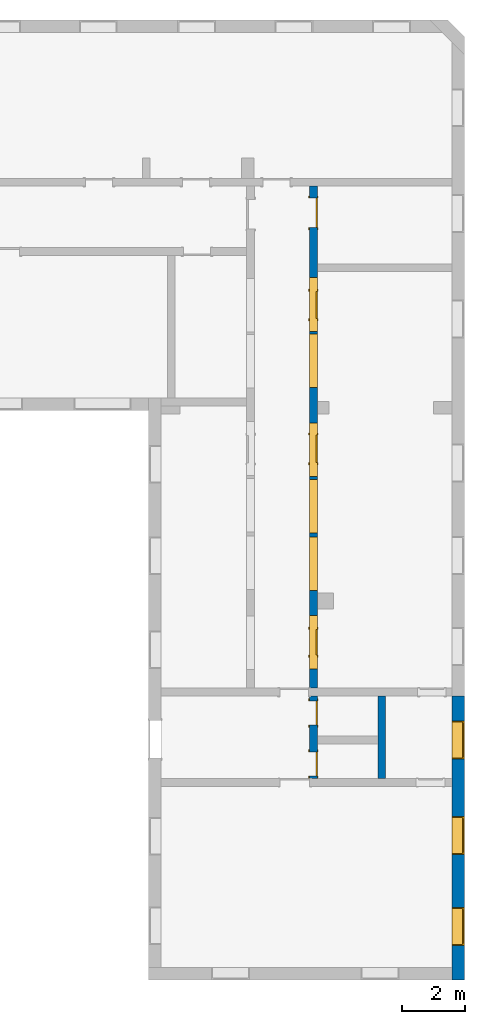
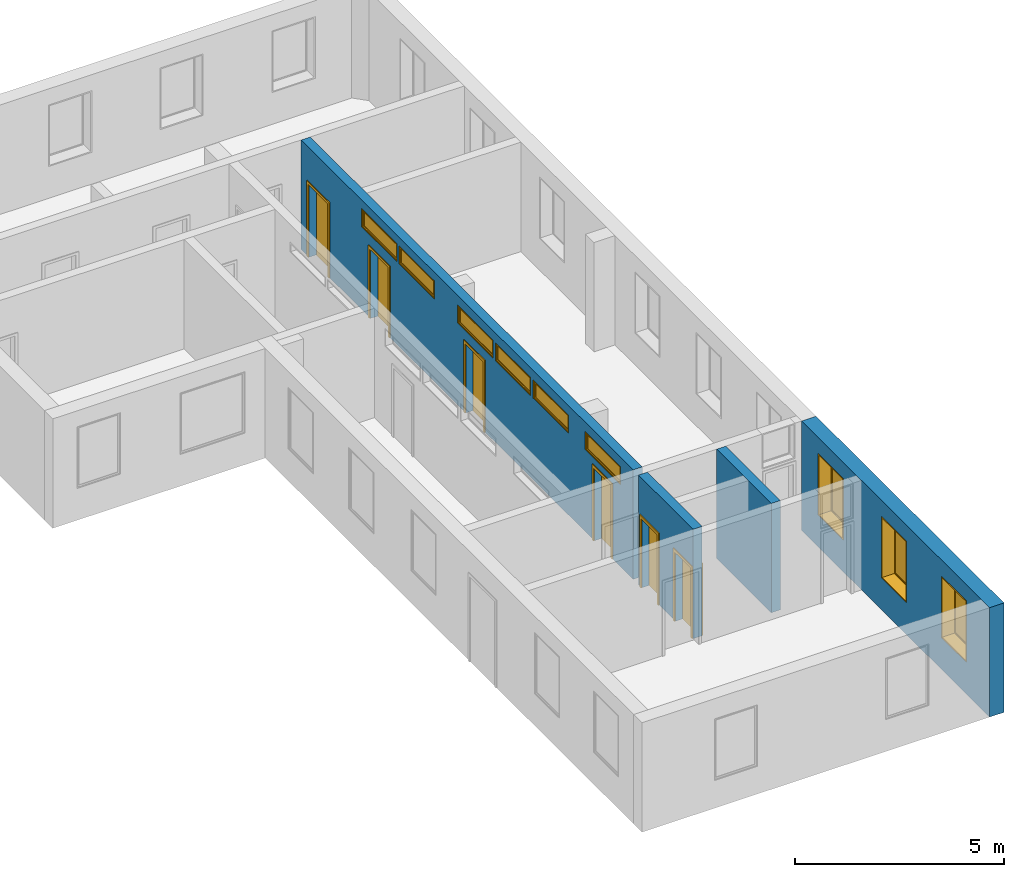
"""IFC2X3 building model written with IfcOpenShell, lengths in millimetres."""

from ifc_helpers import new_model, entity, si_unit, converted_unit, derived_unit, direction, frame, frame_2d, origin, origin_2d_with_axis, place, context, subcontext, project, spatial, polyline, rectangle, outline, extrude, source, transform, mapped, material, material_list, layer, layer_set, layer_usage, type_object, type_shapes, element, fill, save


model = new_model("IFC2X3")

# Units and contexts
model_context = context("Model", 3, precision=0.01, world=origin(), true_north=direction((6.12303176911189e-17, 1.0)))
context_of_model = context(None, 3, precision=0.01, world=origin(), true_north=direction((6.12303176911189e-17, 1.0)))
body_context = subcontext(model_context, "Body", "Model", "MODEL_VIEW")
ifc_project = project(units=[si_unit("LENGTHUNIT", "METRE", prefix="MILLI"), si_unit("AREAUNIT", "SQUARE_METRE"), si_unit("VOLUMEUNIT", "CUBIC_METRE"), converted_unit("PLANEANGLEUNIT", "DEGREE", entity("IfcRatioMeasure", 0.0174532925199433), si_unit("PLANEANGLEUNIT", "RADIAN"), dimensions=[0, 0, 0, 0, 0, 0, 0]), si_unit("MASSUNIT", "GRAM", prefix="KILO"), si_unit("TIMEUNIT", "SECOND"), si_unit("FREQUENCYUNIT", "HERTZ"), si_unit("THERMODYNAMICTEMPERATUREUNIT", "DEGREE_CELSIUS"), derived_unit("THERMALTRANSMITTANCEUNIT", [(si_unit("MASSUNIT", "GRAM", prefix="KILO"), 1), (si_unit("THERMODYNAMICTEMPERATUREUNIT", "KELVIN"), -1), (si_unit("TIMEUNIT", "SECOND"), -3)]), derived_unit("VOLUMETRICFLOWRATEUNIT", [(si_unit("LENGTHUNIT", "METRE"), 3), (si_unit("TIMEUNIT", "SECOND"), -1)]), si_unit("ELECTRICCURRENTUNIT", "AMPERE"), si_unit("ELECTRICVOLTAGEUNIT", "VOLT"), si_unit("POWERUNIT", "WATT"), si_unit("FORCEUNIT", "NEWTON", prefix="KILO"), si_unit("ILLUMINANCEUNIT", "LUX"), si_unit("LUMINOUSFLUXUNIT", "LUMEN"), si_unit("LUMINOUSINTENSITYUNIT", "CANDELA"), si_unit("PRESSUREUNIT", "PASCAL")], contexts=[model_context, context_of_model])

# Site, building, storey
site_placement = place(None, origin())
site = spatial("IfcSite", under=ifc_project, at=site_placement, CompositionType="ELEMENT")
building_placement = place(site_placement, origin())
building = spatial("IfcBuilding", under=site, at=building_placement, CompositionType="ELEMENT")
storey_1_placement = place(building_placement, origin())
storey_1 = spatial("IfcBuildingStorey", under=building, at=storey_1_placement, Name="i Plan", CompositionType="ELEMENT", Elevation=-5.41433564649196e-13)

# Wall, openings
ifc_material_1 = material(Name="Brick, Common")
ifc_layer_1 = layer(ifc_material_1, 400.0)
ifc_layer_set_1 = layer_set([ifc_layer_1], Name="Basic Wall:400mm")
ifc_layer_usage_1 = layer_usage(ifc_layer_set_1, "AXIS2", "NEGATIVE", 200.0)
wall_type_1 = type_object("IfcWallType", Name="Basic Wall:400mm", PredefinedType="STANDARD", material=ifc_layer_set_1)
wall_1_placement = place(storey_1_placement, frame((5302.04003710834, -6813.09629601623, 0.0), z_axis=(0.0, 0.0, 1.0), x_axis=(0.0, -1.0, 0.0)))
wall_1 = element("IfcWallStandardCase", 1, at=wall_1_placement, inside=storey_1, type_object=wall_type_1, material=ifc_layer_usage_1, Name="Basic Wall:400mm", ObjectType="Basic Wall:400mm", context=body_context, shape_type="SweptSolid", body=[
    extrude(rectangle(XDim=9002.31192837113, YDim=400.0, at=frame_2d((4501.15596418557, 2.8421709430404e-14), x_axis=(-1.0, 0.0))), origin(), (0.0, 0.0, 1.0), 3199.99999999984),
])
opening_1_placement = place(wall_1_placement, frame((796.09398524179, -200.0, 930.0)))
opening_1 = element("IfcOpeningElement", 2, at=opening_1_placement, cuts=wall_1, Name="M_Fixed:72_1", ObjectType="Opening", context=body_context, shape_type="SweptSolid", body=[
    extrude(rectangle(XDim=1800.0, YDim=1200.0, at=frame_2d((899.999999999998, 600.0), x_axis=(1.0, 0.0))), frame((0.0, 0.0, 0.0), z_axis=(0.0, 1.0, 0.0), x_axis=(0.0, 0.0, 1.0)), (0.0, 0.0, 1.0), 400.0),
])
opening_2_placement = place(wall_1_placement, frame((3826.09398524179, -200.0, 930.0)))
opening_2 = element("IfcOpeningElement", 3, at=opening_2_placement, cuts=wall_1, Name="M_Fixed:72_1", ObjectType="Opening", context=body_context, shape_type="SweptSolid", body=[
    extrude(rectangle(XDim=1800.0, YDim=1200.0, at=frame_2d((899.999999999998, 600.0), x_axis=(1.0, 0.0))), frame((0.0, 0.0, 0.0), z_axis=(0.0, 1.0, 0.0), x_axis=(0.0, 0.0, 1.0)), (0.0, 0.0, 1.0), 400.0),
])
opening_3_placement = place(wall_1_placement, frame((6702.31192837113, -200.0, 930.0)))
opening_3 = element("IfcOpeningElement", 4, at=opening_3_placement, cuts=wall_1, Name="M_Fixed:72_1", ObjectType="Opening", context=body_context, shape_type="SweptSolid", body=[
    extrude(rectangle(XDim=1800.0, YDim=1200.0, at=frame_2d((899.999999999998, 600.0), x_axis=(1.0, 0.0))), frame((0.0, 0.0, 0.0), z_axis=(0.0, 1.0, 0.0), x_axis=(0.0, 0.0, 1.0)), (0.0, 0.0, 1.0), 400.0),
])

# Storey
storey_2_placement = place(building_placement, frame((0.0, 0.0, 960.0)))
storey_2 = spatial("IfcBuildingStorey", under=building, at=storey_2_placement, Name="Bottom windows", CompositionType="ELEMENT", Elevation=959.999999999999)

# Window
ifc_material_2 = material(Name="Glass")
ifc_material_3 = material(Name="Sash")
ifc_material_list_1 = material_list([ifc_material_2, ifc_material_3])
ifc_material_list_2 = material_list([ifc_material_2, ifc_material_3])
window_style_1 = type_object("IfcWindowStyle", Name="72", ConstructionType="NOTDEFINED", OperationType="NOTDEFINED", ParameterTakesPrecedence=False, Sizeable=False, material=ifc_material_list_2)
shared_shape_1 = source(origin(), body_context, "Body", "SweptSolid", [
    extrude(rectangle(XDim=12.0, YDim=1074.0, at=origin_2d_with_axis()), frame((600.0, 359.0, 63.0), z_axis=(0.0, 0.0, 1.0), x_axis=(0.0, -1.0, 0.0)), (0.0, 0.0, 1.0), 1674.0),
    extrude(outline(polyline([(-581.0, -881.0), (581.0, -881.0), (581.0, 881.0), (-581.0, 881.0), (-581.0, -881.0)]), holes=[polyline([(-537.0, -837.0), (-537.0, 837.0), (537.0, 837.0), (537.0, -837.0), (-537.0, -837.0)])]), frame((600.0, 337.0, 900.0), z_axis=(0.0, 1.0, 0.0), x_axis=(1.0, 0.0, 0.0)), (0.0, 0.0, 1.0), 44.0000000000274),
    extrude(outline(polyline([(-600.0, -900.0), (600.0, -900.0), (600.0, 900.0), (-600.0, 900.0), (-600.0, -900.0)]), holes=[polyline([(-581.0, -881.0), (-581.0, 881.0), (581.0, 881.0), (581.0, -881.0), (-581.0, -881.0)])]), frame((600.0, 337.0, 900.0), z_axis=(0.0, 1.0, 0.0), x_axis=(1.0, 0.0, 0.0)), (0.0, 0.0, 1.0), 63.0000000000275),
    extrude(outline(polyline([(-600.0, -900.0), (600.0, -900.0), (600.0, 900.0), (-600.0, 900.0), (-600.0, -900.0)]), holes=[polyline([(-568.0, -868.0), (-568.0, 868.0), (568.0, 868.0), (568.0, -868.0), (-568.0, -868.0)])]), frame((600.0, 0.0, 900.0), z_axis=(0.0, 1.0, 0.0), x_axis=(1.0, 0.0, 0.0)), (0.0, 0.0, 1.0), 336.999999999973),
])
type_shapes(window_style_1, [shared_shape_1])
window_1_placement = place(opening_1_placement, origin())
window_1 = element("IfcWindow", 5, at=window_1_placement, inside=storey_2, type_object=window_style_1, material=ifc_material_list_1, Name="M_Fixed:72", ObjectType="72", OverallHeight=1800.0, OverallWidth=1200.0, context=body_context, shape_type="MappedRepresentation", body=[
    mapped(shared_shape_1, transform((0.0, 0.0, 0.0), scale=1.0)),
])

fill(opening_1, window_1)

ifc_material_list_3 = material_list([ifc_material_2, ifc_material_3])
window_2_placement = place(opening_2_placement, origin())
window_2 = element("IfcWindow", 6, at=window_2_placement, inside=storey_2, type_object=window_style_1, material=ifc_material_list_3, Name="M_Fixed:72", ObjectType="72", OverallHeight=1800.0, OverallWidth=1200.0, context=body_context, shape_type="MappedRepresentation", body=[
    mapped(shared_shape_1, transform((0.0, 0.0, 0.0), scale=1.0)),
])

fill(opening_2, window_2)

ifc_material_list_4 = material_list([ifc_material_2, ifc_material_3])
window_3_placement = place(opening_3_placement, origin())
window_3 = element("IfcWindow", 7, at=window_3_placement, inside=storey_2, type_object=window_style_1, material=ifc_material_list_4, Name="M_Fixed:72", ObjectType="72", OverallHeight=1800.0, OverallWidth=1200.0, context=body_context, shape_type="MappedRepresentation", body=[
    mapped(shared_shape_1, transform((0.0, 0.0, 0.0), scale=1.0)),
])

fill(opening_3, window_3)

# Wall, openings, doors
ifc_material_4 = material(Name="Default Wall")
ifc_layer_2 = layer(ifc_material_4, 250.0)
ifc_layer_set_2 = layer_set([ifc_layer_2], Name="Basic Wall:250 mm")
ifc_layer_usage_2 = layer_usage(ifc_layer_set_2, "AXIS2", "NEGATIVE", 125.0)
wall_type_2 = type_object("IfcWallType", Name="Basic Wall:250 mm", PredefinedType="STANDARD", material=ifc_layer_set_2)
wall_2_placement = place(storey_1_placement, frame((713.41190722146, 9346.80874326075, 0.0), z_axis=(0.0, 0.0, 1.0), x_axis=(0.0, -1.0, 0.0)))
wall_2 = element("IfcWallStandardCase", 8, at=wall_2_placement, inside=storey_1, type_object=wall_type_2, material=ifc_layer_usage_2, Name="Basic Wall:250 mm", ObjectType="Basic Wall:250 mm", context=body_context, shape_type="SweptSolid", body=[
    extrude(rectangle(XDim=18775.9990245188, YDim=250.0, at=frame_2d((9387.99951225938, -1.4210854715202e-14), x_axis=(-1.0, 0.0))), origin(), (0.0, 0.0, 1.0), 3199.99999999984),
])
opening_4_placement = place(storey_1_placement, frame((713.41190722146, 9346.80874326075, 0.0), z_axis=(0.0, 0.0, 1.0), x_axis=(0.0, -1.0, 0.0)))
element("IfcOpeningElement", 9, at=opening_4_placement, cuts=wall_2, Name="Basic Wall:250 mm 1", ObjectType="Opening", context=body_context, shape_type="SweptSolid", body=[
    extrude(rectangle(XDim=3199.99999999984, YDim=250.0, at=frame_2d((0.0, 3.5527136788005e-14), x_axis=(1.0, 0.0))), frame((16159.905039277, 0.0, 1600.0), z_axis=(-1.0, 0.0, 0.0), x_axis=(0.0, 0.0, 1.0)), (0.0, 0.0, 1.0), 249.999999999999),
])
opening_5_placement = place(wall_2_placement, frame((16319.905039277, -125.0, 0.0)))
opening_5 = element("IfcOpeningElement", 10, at=opening_5_placement, cuts=wall_2, Name="M_Single-Flush:0762 x 2032mm:1", ObjectType="Opening", context=body_context, shape_type="SweptSolid", body=[
    extrude(rectangle(XDim=762.0, YDim=2032.0, at=frame_2d((1016.0, 381.0), x_axis=(0.0, 1.0))), frame((0.0, 0.0, 0.0), z_axis=(0.0, 1.0, 0.0), x_axis=(0.0, 0.0, 1.0)), (0.0, 0.0, 1.0), 250.0),
])
opening_6_placement = place(wall_2_placement, frame((17933.9990245188, -125.0, 0.0)))
opening_6 = element("IfcOpeningElement", 11, at=opening_6_placement, cuts=wall_2, Name="M_Single-Flush:0762 x 2032mm:1", ObjectType="Opening", context=body_context, shape_type="SweptSolid", body=[
    extrude(rectangle(XDim=762.0, YDim=2032.0, at=frame_2d((1016.0, 381.0), x_axis=(0.0, 1.0))), frame((0.0, 0.0, 0.0), z_axis=(0.0, 1.0, 0.0), x_axis=(0.0, 0.0, 1.0)), (0.0, 0.0, 1.0), 250.0),
])
opening_7_placement = place(wall_2_placement, frame((14049.905039277, -125.0, 0.0)))
opening_7 = element("IfcOpeningElement", 12, at=opening_7_placement, cuts=wall_2, Name="M_Single-Flush:0813 x 2134mm:1", ObjectType="Opening", context=body_context, shape_type="SweptSolid", body=[
    extrude(rectangle(XDim=813.0, YDim=2134.0, at=frame_2d((1067.0, 406.5), x_axis=(0.0, 1.0))), frame((0.0, 0.0, 0.0), z_axis=(0.0, 1.0, 0.0), x_axis=(0.0, 0.0, 1.0)), (0.0, 0.0, 1.0), 250.0),
])
opening_8_placement = place(wall_2_placement, frame((7891.40503927696, -125.0, 0.0)))
opening_8 = element("IfcOpeningElement", 13, at=opening_8_placement, cuts=wall_2, Name="M_Single-Flush:0864 x 2032mm:1", ObjectType="Opening", context=body_context, shape_type="SweptSolid", body=[
    extrude(rectangle(XDim=863.999999999999, YDim=2032.0, at=frame_2d((1016.0, 432.0), x_axis=(0.0, 1.0))), frame((0.0, 0.0, 0.0), z_axis=(0.0, 1.0, 0.0), x_axis=(0.0, 0.0, 1.0)), (0.0, 0.0, 1.0), 250.0),
])
opening_9_placement = place(wall_2_placement, frame((3330.0, -125.0, 0.0)))
opening_9 = element("IfcOpeningElement", 14, at=opening_9_placement, cuts=wall_2, Name="M_Single-Flush:0864 x 2032mm:1", ObjectType="Opening", context=body_context, shape_type="SweptSolid", body=[
    extrude(rectangle(XDim=863.999999999999, YDim=2032.0, at=frame_2d((1016.0, 432.0), x_axis=(0.0, 1.0))), frame((0.0, 0.0, 0.0), z_axis=(0.0, 1.0, 0.0), x_axis=(0.0, 0.0, 1.0)), (0.0, 0.0, 1.0), 250.0),
])
opening_10_placement = place(wall_2_placement, frame((380.0, -125.0, 0.0)))
opening_10 = element("IfcOpeningElement", 15, at=opening_10_placement, cuts=wall_2, Name="M_Single-Flush:72 door wide:1", ObjectType="Opening", context=body_context, shape_type="SweptSolid", body=[
    extrude(rectangle(XDim=930.0, YDim=2134.0, at=frame_2d((1067.0, 465.0), x_axis=(0.0, 1.0))), frame((0.0, 0.0, 0.0), z_axis=(0.0, 1.0, 0.0), x_axis=(0.0, 0.0, 1.0)), (0.0, 0.0, 1.0), 250.0),
])
opening_11_placement = place(wall_2_placement, frame((9199.90503927696, 125.0, 2390.0)))
opening_11 = element("IfcOpeningElement", 16, at=opening_11_placement, cuts=wall_2, Name="M_Fixed:1", ObjectType="Opening", context=body_context, shape_type="SweptSolid", body=[
    extrude(rectangle(XDim=529.999999999998, YDim=1700.0, at=frame_2d((264.999999999999, 850.0), x_axis=(1.0, 0.0))), frame((0.0, 0.0, 0.0), z_axis=(0.0, -1.0, 0.0), x_axis=(0.0, 0.0, 1.0)), (0.0, 0.0, 1.0), 250.0),
])
opening_12_placement = place(wall_2_placement, frame((12819.905039277, 125.0, 2390.0)))
opening_12 = element("IfcOpeningElement", 17, at=opening_12_placement, cuts=wall_2, Name="M_Fixed:1", ObjectType="Opening", context=body_context, shape_type="SweptSolid", body=[
    extrude(rectangle(XDim=529.999999999998, YDim=1700.0, at=frame_2d((264.999999999999, 850.0), x_axis=(1.0, 0.0))), frame((0.0, 0.0, 0.0), z_axis=(0.0, -1.0, 0.0), x_axis=(0.0, 0.0, 1.0)), (0.0, 0.0, 1.0), 250.0),
])
opening_13_placement = place(wall_2_placement, frame((4600.0, 125.0, 2420.0)))
opening_13 = element("IfcOpeningElement", 18, at=opening_13_placement, cuts=wall_2, Name="M_Fixed:1", ObjectType="Opening", context=body_context, shape_type="SweptSolid", body=[
    extrude(rectangle(XDim=529.999999999998, YDim=1700.0, at=frame_2d((264.999999999999, 850.0), x_axis=(1.0, 0.0))), frame((0.0, 0.0, 0.0), z_axis=(0.0, -1.0, 0.0), x_axis=(0.0, 0.0, 1.0)), (0.0, 0.0, 1.0), 250.0),
])
opening_14_placement = place(wall_2_placement, frame((6379.90503927696, 125.0, 2420.0)))
opening_14 = element("IfcOpeningElement", 19, at=opening_14_placement, cuts=wall_2, Name="M_Fixed:1", ObjectType="Opening", context=body_context, shape_type="SweptSolid", body=[
    extrude(rectangle(XDim=529.999999999998, YDim=1700.0, at=frame_2d((264.999999999999, 850.0), x_axis=(1.0, 0.0))), frame((0.0, 0.0, 0.0), z_axis=(0.0, -1.0, 0.0), x_axis=(0.0, 0.0, 1.0)), (0.0, 0.0, 1.0), 250.0),
])
opening_15_placement = place(wall_2_placement, frame((10999.905039277, 125.0, 2390.0)))
opening_15 = element("IfcOpeningElement", 20, at=opening_15_placement, cuts=wall_2, Name="M_Fixed:1", ObjectType="Opening", context=body_context, shape_type="SweptSolid", body=[
    extrude(rectangle(XDim=529.999999999998, YDim=1700.0, at=frame_2d((264.999999999999, 850.0), x_axis=(1.0, 0.0))), frame((0.0, 0.0, 0.0), z_axis=(0.0, -1.0, 0.0), x_axis=(0.0, 0.0, 1.0)), (0.0, 0.0, 1.0), 250.0),
])
opening_16_placement = place(wall_2_placement, frame((15309.905039277, 125.0, 2397.27318733261)))
opening_16 = element("IfcOpeningElement", 21, at=opening_16_placement, cuts=wall_2, Name="M_Fixed:1", ObjectType="Opening", context=body_context, shape_type="SweptSolid", body=[
    extrude(rectangle(XDim=529.999999999998, YDim=1700.0, at=frame_2d((264.999999999999, 850.0), x_axis=(1.0, 0.0))), frame((0.0, 0.0, 0.0), z_axis=(0.0, -1.0, 0.0), x_axis=(0.0, 0.0, 1.0)), (0.0, 0.0, 1.0), 250.0),
])
ifc_material_5 = material(Name="Door - Frame")
ifc_material_6 = material(Name="Door - Panel")
ifc_material_list_5 = material_list([ifc_material_5, ifc_material_6])
ifc_material_list_6 = material_list([ifc_material_5, ifc_material_6])
door_style_1 = type_object("IfcDoorStyle", Name="72 door wide", ConstructionType="NOTDEFINED", OperationType="SINGLE_SWING_RIGHT", ParameterTakesPrecedence=False, Sizeable=False, material=ifc_material_list_6)
shared_shape_2 = source(origin(), body_context, "Body", "SweptSolid", [
    extrude(outline(polyline([(-541.0, -1124.0), (541.0, -1124.0), (541.0, 1086.0), (465.0, 1086.0), (465.0, -1048.0), (-465.0, -1048.0), (-465.0, 1086.0), (-541.0, 1086.0), (-541.0, -1124.0)])), frame((465.0, 250.0, 1086.0), z_axis=(0.0, 1.0, 0.0), x_axis=(1.0, 0.0, 0.0)), (0.0, 0.0, 1.0), 24.9999999999945),
    extrude(outline(polyline([(-1124.0, -541.0), (1086.0, -541.0), (1086.0, -465.0), (-1048.0, -465.0), (-1048.0, 465.0), (1086.0, 465.0), (1086.0, 541.0), (-1124.0, 541.0), (-1124.0, -541.0)])), frame((465.0, -25.0, 1086.0), z_axis=(0.0, 1.0, 0.0), x_axis=(0.0, 0.0, -1.0)), (0.0, 0.0, 1.0), 25.0000000000056),
    extrude(rectangle(XDim=51.0, YDim=930.0, at=frame_2d((5.32907051820075e-15, 0.0), x_axis=(1.0, 0.0))), frame((465.0, 224.499999999999, 0.0), z_axis=(0.0, 0.0, 1.0), x_axis=(0.0, 1.0, 0.0)), (0.0, 0.0, 1.0), 2134.0),
])
type_shapes(door_style_1, [shared_shape_2])
door_1_placement = place(opening_10_placement, origin())
door_1 = element("IfcDoor", 22, at=door_1_placement, inside=storey_1, type_object=door_style_1, material=ifc_material_list_5, Name="M_Single-Flush:72 door wide", ObjectType="72 door wide", OverallHeight=2134.0, OverallWidth=930.0, context=body_context, shape_type="MappedRepresentation", body=[
    mapped(shared_shape_2, transform((0.0, 0.0, 0.0), scale=1.0)),
])
fill(opening_10, door_1)
ifc_material_list_7 = material_list([ifc_material_5, ifc_material_6])
ifc_material_list_8 = material_list([ifc_material_5, ifc_material_6])
door_style_2 = type_object("IfcDoorStyle", Name="0762 x 2032mm", ConstructionType="NOTDEFINED", OperationType="SINGLE_SWING_RIGHT", ParameterTakesPrecedence=False, Sizeable=False, material=ifc_material_list_8)
shared_shape_3 = source(origin(), body_context, "Body", "SweptSolid", [
    extrude(outline(polyline([(-457.0, -1073.0), (457.0, -1073.0), (457.0, 1035.0), (381.0, 1035.0), (381.0, -997.0), (-381.0, -997.0), (-381.0, 1035.0), (-457.0, 1035.0), (-457.0, -1073.0)])), frame((381.0, 250.0, 1035.0), z_axis=(0.0, 1.0, 0.0), x_axis=(1.0, 0.0, 0.0)), (0.0, 0.0, 1.0), 24.9999999999945),
    extrude(outline(polyline([(-1073.0, -457.0), (1035.0, -457.0), (1035.0, -381.0), (-997.0, -381.0), (-997.0, 381.0), (1035.0, 381.0), (1035.0, 457.0), (-1073.0, 457.0), (-1073.0, -457.0)])), frame((381.0, -25.0, 1035.0), z_axis=(0.0, 1.0, 0.0), x_axis=(0.0, 0.0, -1.0)), (0.0, 0.0, 1.0), 25.0000000000056),
    extrude(rectangle(XDim=51.0, YDim=762.0, at=frame_2d((5.32907051820075e-15, 0.0), x_axis=(1.0, 0.0))), frame((381.0, 224.499999999999, 0.0), z_axis=(0.0, 0.0, 1.0), x_axis=(0.0, 1.0, 0.0)), (0.0, 0.0, 1.0), 2032.0),
])
type_shapes(door_style_2, [shared_shape_3])
door_2_placement = place(opening_5_placement, origin())
door_2 = element("IfcDoor", 23, at=door_2_placement, inside=storey_1, type_object=door_style_2, material=ifc_material_list_7, Name="M_Single-Flush:0762 x 2032mm", ObjectType="0762 x 2032mm", OverallHeight=2032.0, OverallWidth=762.0, context=body_context, shape_type="MappedRepresentation", body=[
    mapped(shared_shape_3, transform((0.0, 0.0, 0.0), scale=1.0)),
])
fill(opening_5, door_2)
ifc_material_list_9 = material_list([ifc_material_5, ifc_material_6])
door_3_placement = place(opening_6_placement, origin())
door_3 = element("IfcDoor", 24, at=door_3_placement, inside=storey_1, type_object=door_style_2, material=ifc_material_list_9, Name="M_Single-Flush:0762 x 2032mm", ObjectType="0762 x 2032mm", OverallHeight=2032.0, OverallWidth=762.0, context=body_context, shape_type="MappedRepresentation", body=[
    mapped(shared_shape_3, transform((0.0, 0.0, 0.0), scale=1.0)),
])
fill(opening_6, door_3)
ifc_material_list_10 = material_list([ifc_material_5, ifc_material_6])
ifc_material_list_11 = material_list([ifc_material_5, ifc_material_6])
door_style_3 = type_object("IfcDoorStyle", Name="0813 x 2134mm", ConstructionType="NOTDEFINED", OperationType="SINGLE_SWING_RIGHT", ParameterTakesPrecedence=False, Sizeable=False, material=ifc_material_list_11)
shared_shape_4 = source(origin(), body_context, "Body", "SweptSolid", [
    extrude(outline(polyline([(-482.5, -1124.0), (482.5, -1124.0), (482.5, 1086.0), (406.5, 1086.0), (406.5, -1048.0), (-406.5, -1048.0), (-406.5, 1086.0), (-482.5, 1086.0), (-482.5, -1124.0)])), frame((406.500000000001, 250.0, 1086.0), z_axis=(0.0, 1.0, 0.0), x_axis=(1.0, 0.0, 0.0)), (0.0, 0.0, 1.0), 24.9999999999945),
    extrude(outline(polyline([(-1124.0, -482.499999999997), (1086.0, -482.499999999997), (1086.0, -406.500000000007), (-1048.0, -406.500000000007), (-1048.0, 406.500000000002), (1086.0, 406.500000000002), (1086.0, 482.500000000003), (-1124.0, 482.500000000003), (-1124.0, -482.499999999997)])), frame((406.500000000003, -25.0, 1086.0), z_axis=(0.0, 1.0, 0.0), x_axis=(0.0, 0.0, -1.0)), (0.0, 0.0, 1.0), 25.0000000000056),
    extrude(rectangle(XDim=51.0, YDim=813.0, at=frame_2d((5.32907051820075e-15, 0.0), x_axis=(1.0, 0.0))), frame((406.5, 224.499999999999, 0.0), z_axis=(0.0, 0.0, 1.0), x_axis=(0.0, 1.0, 0.0)), (0.0, 0.0, 1.0), 2134.0),
])
type_shapes(door_style_3, [shared_shape_4])
door_4_placement = place(opening_7_placement, origin())
door_4 = element("IfcDoor", 25, at=door_4_placement, inside=storey_1, type_object=door_style_3, material=ifc_material_list_10, Name="M_Single-Flush:0813 x 2134mm", ObjectType="0813 x 2134mm", OverallHeight=2134.0, OverallWidth=813.0, context=body_context, shape_type="MappedRepresentation", body=[
    mapped(shared_shape_4, transform((0.0, 0.0, 0.0), scale=1.0)),
])
fill(opening_7, door_4)
ifc_material_list_12 = material_list([ifc_material_5, ifc_material_6])
ifc_material_list_13 = material_list([ifc_material_5, ifc_material_6])
door_style_4 = type_object("IfcDoorStyle", Name="0864 x 2032mm", ConstructionType="NOTDEFINED", OperationType="SINGLE_SWING_RIGHT", ParameterTakesPrecedence=False, Sizeable=False, material=ifc_material_list_13)
shared_shape_5 = source(origin(), body_context, "Body", "SweptSolid", [
    extrude(outline(polyline([(-508.0, -1073.0), (508.0, -1073.0), (508.0, 1035.0), (432.0, 1035.0), (432.0, -997.0), (-432.0, -997.0), (-432.0, 1035.0), (-508.0, 1035.0), (-508.0, -1073.0)])), frame((432.0, 250.0, 1035.0), z_axis=(0.0, 1.0, 0.0), x_axis=(1.0, 0.0, 0.0)), (0.0, 0.0, 1.0), 24.9999999999945),
    extrude(outline(polyline([(-1073.0, -508.0), (1035.0, -508.0), (1035.0, -432.0), (-997.0, -432.0), (-997.0, 432.0), (1035.0, 432.0), (1035.0, 508.0), (-1073.0, 508.0), (-1073.0, -508.0)])), frame((432.0, -25.0, 1035.0), z_axis=(0.0, 1.0, 0.0), x_axis=(0.0, 0.0, -1.0)), (0.0, 0.0, 1.0), 25.0000000000056),
    extrude(rectangle(XDim=51.0, YDim=864.0, at=frame_2d((5.32907051820075e-15, 0.0), x_axis=(1.0, 0.0))), frame((432.0, 224.499999999999, 0.0), z_axis=(0.0, 0.0, 1.0), x_axis=(0.0, 1.0, 0.0)), (0.0, 0.0, 1.0), 2032.0),
])
type_shapes(door_style_4, [shared_shape_5])
door_5_placement = place(opening_8_placement, origin())
door_5 = element("IfcDoor", 26, at=door_5_placement, inside=storey_1, type_object=door_style_4, material=ifc_material_list_12, Name="M_Single-Flush:0864 x 2032mm", ObjectType="0864 x 2032mm", OverallHeight=2032.0, OverallWidth=864.0, context=body_context, shape_type="MappedRepresentation", body=[
    mapped(shared_shape_5, transform((0.0, 0.0, 0.0), scale=1.0)),
])
fill(opening_8, door_5)
ifc_material_list_14 = material_list([ifc_material_5, ifc_material_6])
door_6_placement = place(opening_9_placement, origin())
door_6 = element("IfcDoor", 27, at=door_6_placement, inside=storey_1, type_object=door_style_4, material=ifc_material_list_14, Name="M_Single-Flush:0864 x 2032mm", ObjectType="0864 x 2032mm", OverallHeight=2032.0, OverallWidth=864.0, context=body_context, shape_type="MappedRepresentation", body=[
    mapped(shared_shape_5, transform((0.0, 0.0, 0.0), scale=1.0)),
])
fill(opening_9, door_6)

# Storey
storey_3_placement = place(building_placement, frame((0.0, 0.0, -500.0)))
storey_3 = spatial("IfcBuildingStorey", under=building, at=storey_3_placement, Name="Level 1", CompositionType="ELEMENT", Elevation=-500.000000000001)

# Window
ifc_material_list_15 = material_list([ifc_material_2, ifc_material_3])
ifc_material_list_16 = material_list([ifc_material_2, ifc_material_3])
window_style_2 = type_object("IfcWindowStyle", ConstructionType="NOTDEFINED", OperationType="NOTDEFINED", ParameterTakesPrecedence=False, Sizeable=False, material=ifc_material_list_16)
shared_shape_6 = source(origin(), body_context, "Body", "SweptSolid", [
    extrude(rectangle(XDim=12.0, YDim=1574.0, at=frame_2d((-8.43769498715119e-15, 0.0), x_axis=(1.0, 0.0))), frame((850.0, 209.0, 63.0), z_axis=(0.0, 0.0, 1.0), x_axis=(0.0, -1.0, 0.0)), (0.0, 0.0, 1.0), 404.000000000007),
    extrude(outline(polyline([(-831.0, -246.0), (831.0, -246.0), (831.0, 246.0), (-831.0, 246.0), (-831.0, -246.0)]), holes=[polyline([(-787.0, -202.0), (-787.0, 202.0), (787.0, 202.0), (787.0, -202.0), (-787.0, -202.0)])]), frame((850.0, 187.0, 265.0), z_axis=(0.0, 1.0, 0.0), x_axis=(1.0, 0.0, 0.0)), (0.0, 0.0, 1.0), 44.0000000000274),
    extrude(outline(polyline([(-850.0, -265.0), (850.0, -265.0), (850.0, 265.0), (-850.0, 265.0), (-850.0, -265.0)]), holes=[polyline([(-831.0, -246.0), (-831.0, 246.0), (831.0, 246.0), (831.0, -246.0), (-831.0, -246.0)])]), frame((850.0, 187.0, 265.0), z_axis=(0.0, 1.0, 0.0), x_axis=(1.0, 0.0, 0.0)), (0.0, 0.0, 1.0), 63.0000000000274),
    extrude(outline(polyline([(-850.0, -265.0), (850.0, -265.0), (850.0, 265.0), (-850.0, 265.0), (-850.0, -265.0)]), holes=[polyline([(-818.0, -233.0), (-818.0, 233.0), (818.0, 233.0), (818.0, -233.0), (-818.0, -233.0)])]), frame((850.0, 0.0, 265.0), z_axis=(0.0, 1.0, 0.0), x_axis=(1.0, 0.0, 0.0)), (0.0, 0.0, 1.0), 186.999999999973),
])
type_shapes(window_style_2, [shared_shape_6])
window_4_placement = place(opening_13_placement, frame((0.0, 0.0, 0.0), z_axis=(0.0, 0.0, 1.0), x_axis=(-1.0, 0.0, 0.0)))
window_4 = element("IfcWindow", 28, at=window_4_placement, inside=storey_3, type_object=window_style_2, material=ifc_material_list_15, Name="M_Fixed", OverallHeight=529.999999999998, OverallWidth=1700.0, context=body_context, shape_type="MappedRepresentation", body=[
    mapped(shared_shape_6, transform((0.0, 0.0, 0.0), scale=1.0)),
])

fill(opening_13, window_4)

ifc_material_list_17 = material_list([ifc_material_2, ifc_material_3])
window_5_placement = place(opening_16_placement, frame((0.0, 0.0, 0.0), z_axis=(0.0, 0.0, 1.0), x_axis=(-1.0, 0.0, 0.0)))
window_5 = element("IfcWindow", 29, at=window_5_placement, inside=storey_2, type_object=window_style_2, material=ifc_material_list_17, Name="M_Fixed", OverallHeight=529.999999999998, OverallWidth=1700.0, context=body_context, shape_type="MappedRepresentation", body=[
    mapped(shared_shape_6, transform((0.0, 0.0, 0.0), scale=1.0)),
])

fill(opening_16, window_5)

ifc_material_list_18 = material_list([ifc_material_2, ifc_material_3])
ifc_material_list_19 = material_list([ifc_material_2, ifc_material_3])
window_style_3 = type_object("IfcWindowStyle", ConstructionType="NOTDEFINED", OperationType="NOTDEFINED", ParameterTakesPrecedence=False, Sizeable=False, material=ifc_material_list_19)
shared_shape_7 = source(origin(), body_context, "Body", "SweptSolid", [
    extrude(rectangle(XDim=1574.0, YDim=12.0, at=frame_2d((0.0, -8.43769498715119e-15), x_axis=(1.0, 0.0))), frame((850.0, 235.0, 63.0), z_axis=(0.0, 0.0, 1.0), x_axis=(-1.0, 0.0, 0.0)), (0.0, 0.0, 1.0), 404.000000000007),
    extrude(outline(polyline([(-831.0, -246.0), (831.0, -246.0), (831.0, 246.0), (-831.0, 246.0), (-831.0, -246.0)]), holes=[polyline([(-787.0, -202.0), (-787.0, 202.0), (787.0, 202.0), (787.0, -202.0), (-787.0, -202.0)])]), frame((850.0, 257.0, 265.0), z_axis=(0.0, -1.0, 0.0), x_axis=(-1.0, 0.0, 0.0)), (0.0, 0.0, 1.0), 44.0000000000274),
    extrude(outline(polyline([(-850.0, -265.0), (850.0, -265.0), (850.0, 265.0), (-850.0, 265.0), (-850.0, -265.0)]), holes=[polyline([(-831.0, -246.0), (-831.0, 246.0), (831.0, 246.0), (831.0, -246.0), (-831.0, -246.0)])]), frame((850.0, 276.0, 265.0), z_axis=(0.0, -1.0, 0.0), x_axis=(-1.0, 0.0, 0.0)), (0.0, 0.0, 1.0), 63.0000000000274),
    extrude(outline(polyline([(-850.0, -265.0), (850.0, -265.0), (850.0, 265.0), (-850.0, 265.0), (-850.0, -265.0)]), holes=[polyline([(-818.0, -233.0), (-818.0, 233.0), (818.0, 233.0), (818.0, -233.0), (-818.0, -233.0)])]), frame((850.0, 213.0, 265.0), z_axis=(0.0, -1.0, 0.0), x_axis=(-1.0, 0.0, 0.0)), (0.0, 0.0, 1.0), 186.999999999973),
])
type_shapes(window_style_3, [shared_shape_7])
window_6_placement = place(opening_14_placement, frame((0.0, 26.0, 0.0), z_axis=(0.0, 0.0, 1.0), x_axis=(-1.0, 0.0, 0.0)))
window_6 = element("IfcWindow", 30, at=window_6_placement, inside=storey_3, type_object=window_style_3, material=ifc_material_list_18, Name="M_Fixed", OverallHeight=529.999999999998, OverallWidth=1700.0, context=body_context, shape_type="MappedRepresentation", body=[
    mapped(shared_shape_7, transform((0.0, 0.0, 0.0), scale=1.0)),
])

fill(opening_14, window_6)

ifc_material_list_20 = material_list([ifc_material_2, ifc_material_3])
window_7_placement = place(opening_11_placement, frame((0.0, 26.0, 0.0), z_axis=(0.0, 0.0, 1.0), x_axis=(-1.0, 0.0, 0.0)))
window_7 = element("IfcWindow", 31, at=window_7_placement, inside=storey_3, type_object=window_style_3, material=ifc_material_list_20, Name="M_Fixed", OverallHeight=529.999999999998, OverallWidth=1700.0, context=body_context, shape_type="MappedRepresentation", body=[
    mapped(shared_shape_7, transform((0.0, 0.0, 0.0), scale=1.0)),
])

fill(opening_11, window_7)

ifc_material_list_21 = material_list([ifc_material_2, ifc_material_3])
window_8_placement = place(opening_15_placement, frame((0.0, 26.0, 0.0), z_axis=(0.0, 0.0, 1.0), x_axis=(-1.0, 0.0, 0.0)))
window_8 = element("IfcWindow", 32, at=window_8_placement, inside=storey_3, type_object=window_style_3, material=ifc_material_list_21, Name="M_Fixed", OverallHeight=529.999999999998, OverallWidth=1700.0, context=body_context, shape_type="MappedRepresentation", body=[
    mapped(shared_shape_7, transform((0.0, 0.0, 0.0), scale=1.0)),
])

fill(opening_15, window_8)

ifc_material_list_22 = material_list([ifc_material_2, ifc_material_3])
window_9_placement = place(opening_12_placement, frame((0.0, 26.0, 0.0), z_axis=(0.0, 0.0, 1.0), x_axis=(-1.0, 0.0, 0.0)))
window_9 = element("IfcWindow", 33, at=window_9_placement, inside=storey_3, type_object=window_style_3, material=ifc_material_list_22, Name="M_Fixed", OverallHeight=529.999999999998, OverallWidth=1700.0, context=body_context, shape_type="MappedRepresentation", body=[
    mapped(shared_shape_7, transform((0.0, 0.0, 0.0), scale=1.0)),
])

fill(opening_12, window_9)

# Wall
ifc_layer_usage_3 = layer_usage(ifc_layer_set_2, "AXIS2", "NEGATIVE", 125.0)
wall_3_placement = place(storey_1_placement, frame((2877.04003710833, -9429.19028125801, 0.0), z_axis=(0.0, 0.0, 1.0), x_axis=(0.0, 1.0, 0.0)))
element("IfcWallStandardCase", 34, at=wall_3_placement, inside=storey_1, type_object=wall_type_2, material=ifc_layer_usage_3, Name="Basic Wall:250 mm", ObjectType="Basic Wall:250 mm", context=body_context, shape_type="SweptSolid", body=[
    extrude(rectangle(XDim=2616.09398524179, YDim=249.999999999999, at=frame_2d((1308.0469926209, 0.0), x_axis=(-1.0, 0.0))), origin(), (0.0, 0.0, 1.0), 3199.99999999984),
])

save(model, "model.ifc")
